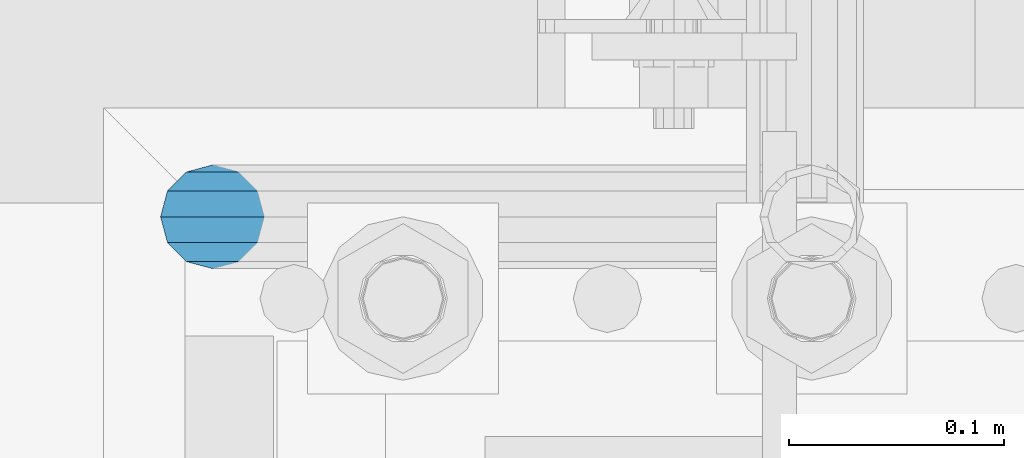
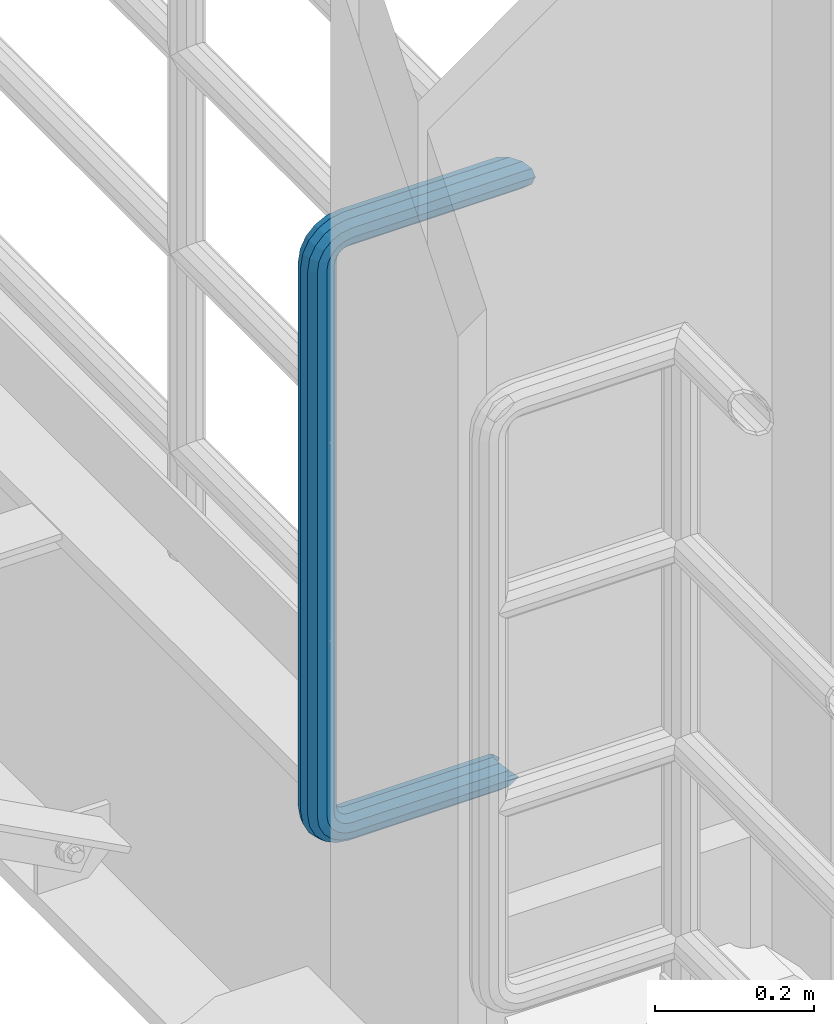
# One storey, part 990 of 1876: 1 beam, 1 element without a shape of its own.
"""IFC2X3 building model written with IfcOpenShell, lengths in millimetres."""

from ifc_helpers import new_model, si_unit, frame, origin_with_axes, place, context, subcontext, project, spatial, faceted_brep, material, type_object, element, aggregate, save


model = new_model("IFC2X3")

# Units and contexts
model_context = context("Model", 3, precision=1e-05, world=origin_with_axes())
body_context = subcontext(model_context, "Body", "Model", "MODEL_VIEW")
ifc_project = project(units=[si_unit("LENGTHUNIT", "METRE", prefix="MILLI"), si_unit("AREAUNIT", "SQUARE_METRE"), si_unit("VOLUMEUNIT", "CUBIC_METRE"), si_unit("MASSUNIT", "GRAM", prefix="KILO"), si_unit("TIMEUNIT", "SECOND"), si_unit("PLANEANGLEUNIT", "RADIAN"), si_unit("SOLIDANGLEUNIT", "STERADIAN"), si_unit("THERMODYNAMICTEMPERATUREUNIT", "DEGREE_CELSIUS"), si_unit("LUMINOUSINTENSITYUNIT", "LUMEN")], contexts=[model_context])

# Site, building, storey
site_placement = place(None, origin_with_axes())
site = spatial("IfcSite", under=ifc_project, at=site_placement, CompositionType="ELEMENT")
building_placement = place(site_placement, origin_with_axes())
building = spatial("IfcBuilding", under=site, at=building_placement, Name="Undefined", CompositionType="ELEMENT")
storey_placement = place(building_placement, origin_with_axes())
storey = spatial("IfcBuildingStorey", under=building, at=storey_placement, Name="Undefined", CompositionType="ELEMENT", Elevation=0.0)

# Assembly, beam
assembly_placement = place(storey_placement, origin_with_axes())
assembly = element("IfcElementAssembly", 1, at=assembly_placement, inside=storey, Name="RAIL", AssemblyPlace="NOTDEFINED", PredefinedType="RIGID_FRAME")
ifc_material = material()
beam_type = type_object("IfcBeamType", Name="PIPE1-1/2SCH40", PredefinedType="NOTDEFINED")
beam_placement = place(assembly_placement, frame((7620.00000000001, -4356.1, 9229.725), z_axis=(0.0, 0.0, 1.0), x_axis=(-1.0, 0.0, 0.0)))
beam = element("IfcBeam", 2, at=beam_placement, type_object=beam_type, material=ifc_material, Name="RAIL", ObjectType="PIPE1-1/2SCH40", context=body_context, shape_type="Brep", body=[
    faceted_brep([(1.20714750983051e-12, 24.1299999999974, -914.399963378906), (12.0650000000014, 20.8971929933159, -926.464963378905), (12.0650000000014, 20.8971929933177, -902.334963378908), (12.0650000000014, -20.8971929933195, -902.334963378908), (12.0650000000014, -20.8971929933195, -926.464963378905), (1.52133659548828e-12, -24.130000000001, -914.399963378906), (20.8971929933199, -12.0650000000023, -893.502770385589), (20.8971929933199, -12.0650000000005, -898.533841947723), (15.2545715621378, -17.7076214311819, -904.176463378906), (12.5151929933181, -20.4470000000019, -914.399963378906), (15.2545715621376, -17.7076214311819, -924.623463378906), (20.8971929933199, -12.0650000000005, -930.26608481009), (20.8971929933199, -12.0650000000023, -935.297156372224), (24.1300000000014, -1.81898940354586e-12, -934.846963378906), (24.1300000000014, -1.81898940354586e-12, -938.529963378907), (21.3906214311813, -10.2235000000019, -932.107584810088), (21.3906214311823, 10.2234999999982, -932.107584810088), (20.8971929933199, 12.0650000000005, -930.266084810086), (20.8971929933199, 12.0649999999987, -935.297156372224), (15.2545715621413, 17.7076214311783, -924.623463378906), (12.5151929933216, 20.4469999999983, -914.399963378906), (15.2545715621411, 17.7076214311783, -904.176463378906), (20.8971929933199, 12.0650000000005, -898.533841947727), (20.8971929933199, 12.0649999999987, -893.502770385589), (21.3906214311822, 10.2234999999982, -896.692341947724), (24.1300000000014, 0.0, -893.952963378906), (24.1300000000014, 0.0, -890.269963378905), (21.3906214311814, -10.2235000000019, -896.692341947724), (241.299995422363, -20.8971929933177, 12.0649999999987), (241.299995422363, -24.1299999999992, 0.0), (253.073542436527, -24.1299999999992, -1.86474665447167), (256.801832473661, -20.8971929933177, 9.60975021462946), (241.299995422363, -12.0650000000005, 20.8971929933177), (259.531130206197, -12.0650000000005, 18.0096649141014), (241.299995422363, 0.0, 24.130000000001), (260.530122510796, 0.0, 21.084247083727), (241.299995422363, 12.0650000000005, 20.8971929933177), (259.531130206197, 12.0650000000005, 18.0096649141014), (241.299995422363, 20.8971929933177, 12.0649999999987), (256.801832473661, 20.8971929933177, 9.60975021462946), (241.299995422363, 24.1299999999992, 0.0), (253.073542436527, 24.1299999999992, -1.86474665447167), (241.299995422363, 20.8971929933177, -12.0649999999987), (249.345252399393, 20.8971929933177, -13.3392435235728), (241.299995422363, 12.0650000000005, -20.8971929933177), (246.615954666858, 12.0650000000005, -21.7391582230448), (241.299995422363, 0.0, -24.130000000001), (245.616962362259, 0.0, -24.8137403926739), (241.299995422363, -12.0650000000005, -20.8971929933177), (246.615954666858, -12.0650000000005, -21.7391582230448), (241.299995422363, -20.8971929933177, -12.0649999999987), (249.345252399393, -20.8971929933177, -13.3392435235728), (267.334993896485, 20.8971929933177, -38.0999984741211), (279.399993896485, 24.1299999999992, -38.0999984741211), (279.399993896484, 24.1299999999992, -876.299964904785), (267.334993896484, 20.8971929933177, -876.299964904785), (291.464993896486, 20.8971929933177, -38.0999984741211), (291.464993896484, 20.8971929933177, -876.299964904785), (300.297186889804, 12.0650000000005, -38.0999984741211), (300.297186889803, 12.0650000000005, -876.299964904785), (303.529993896486, 0.0, -38.0999984741211), (303.529993896484, 0.0, -876.299964904785), (300.297186889804, -12.0650000000005, -38.0999984741211), (300.297186889803, -12.0650000000005, -876.299964904785), (291.464993896486, -20.8971929933177, -38.0999984741211), (291.464993896484, -20.8971929933177, -876.299964904785), (279.399993896484, -24.1299999999992, -38.0999984741211), (279.399993896484, -24.1299999999992, -876.299964904785), (267.334993896485, -20.8971929933177, -38.0999984741211), (267.334993896484, -20.8971929933177, -876.299964904785), (258.502800903167, -12.0650000000005, -38.0999984741211), (258.502800903166, -12.0650000000005, -876.299964904785), (255.269993896485, 0.0, -38.0999984741211), (255.269993896484, 0.0, -876.299964904785), (258.502800903167, 12.0650000000005, -38.0999984741211), (258.502800903166, 12.0650000000005, -876.299964904785), (257.660835673438, 12.0650000000005, -881.615924149282), (254.586253503809, 0.0, -880.616931844681), (257.660835673438, -12.0650000000005, -881.615924149282), (266.06075037291, -20.8971929933177, -884.345221881817), (277.535247242011, -24.130000000001, -888.073511918952), (289.009744111112, -20.8971929933195, -891.801801956084), (297.409658810584, -12.0650000000005, -894.531099688622), (300.484240980214, 0.0, -895.53009199322), (297.409658810584, 12.0650000000005, -894.531099688622), (289.009744111112, 20.8971929933177, -891.801801956084), (277.535247242011, 24.1299999999992, -888.073511918952), (266.06075037291, 20.8971929933177, -884.345221881817), (241.299995422364, -1.81898940354586e-12, -938.529963378911), (241.299995422364, -12.0650000000005, -935.297156372228), (241.299995422364, -20.8971929933195, -926.464963378909), (241.299995422363, -24.130000000001, -914.399963378906), (241.299995422363, -20.8971929933195, -902.334963378908), (241.299995422363, -12.0650000000005, -893.502770385589), (241.299995422363, 0.0, -890.269963378909), (241.299995422364, 20.8971929933177, -926.464963378909), (241.299995422364, 12.0649999999987, -935.297156372228), (241.299995422364, 24.1299999999992, -914.39996337891), (241.299995422363, 20.8971929933177, -902.334963378908), (241.299995422363, 12.0649999999987, -893.502770385589), (260.530122510801, 0.0, -935.484210462637), (259.531130206202, 12.0649999999987, -932.409628293008), (259.531130206201, -12.0650000000005, -932.409628293008), (256.801832473666, -20.8971929933195, -924.009713593536), (253.07354243653, -24.130000000001, -912.535216724435), (249.345252399395, -20.8971929933195, -901.060719855333), (246.615954666859, -12.0650000000005, -892.660805155861), (245.61696236226, 0.0, -889.586222986232), (246.615954666859, 12.0649999999987, -892.660805155861), (249.345252399395, 20.8971929933177, -901.060719855333), (253.07354243653, 24.1299999999992, -912.535216724435), (256.801832473666, 20.8971929933177, -924.009713593536), (275.977674493594, 12.0649999999987, -924.029695422345), (270.786241706733, 20.8971929933177, -916.884301193139), (277.877870775644, 0.0, -926.645091230272), (275.977674493608, -12.0650000000005, -924.029695422334), (270.786241706733, -20.8971929933195, -916.884301193139), (263.694612637823, -24.130000000001, -907.123511156005), (256.602983568912, -20.8971929933195, -897.362721118872), (251.411550782037, -12.0650000000005, -890.21732688968), (249.511354500001, 0.0, -887.601931081743), (251.411550782037, 12.0650000000005, -890.21732688968), (256.602983568912, 20.8971929933177, -897.362721118872), (263.694612637823, 24.1299999999992, -907.123511156005), (281.884331710718, 20.8971929933177, -905.786211189152), (272.123541673585, 24.1299999999992, -898.694582120243), (289.029725939912, 12.0650000000005, -910.977643976028), (291.645121747852, 0.0, -912.877840258065), (289.029725939912, -12.0650000000005, -910.977643976028), (281.884331710718, -20.8971929933195, -905.786211189152), (272.123541673585, -24.130000000001, -898.694582120243), (262.362751636451, -20.8971929933195, -891.602953051333), (255.217357407258, -12.0650000000005, -886.411520264461), (252.601961599318, 0.0, -884.511323982424), (255.217357407258, 12.0650000000005, -886.411520264461), (262.362751636451, 20.8971929933177, -891.602953051333), (266.060750372911, 20.8971929933177, -30.0547414970897), (257.660835673439, 12.0650000000005, -32.7840392296275), (277.535247242011, 24.1299999999992, -26.3264514599541), (289.009744111112, 20.8971929933177, -22.5981614228222), (297.409658810584, 12.0650000000005, -19.8688636902843), (300.484240980213, 0.0, -18.8698713856866), (297.409658810584, -12.0650000000005, -19.8688636902843), (289.009744111112, -20.8971929933177, -22.5981614228222), (277.535247242011, -24.1299999999992, -26.3264514599541), (266.060750372911, -20.8971929933177, -30.0547414970897), (257.660835673439, -12.0650000000005, -32.7840392296275), (254.58625350381, 0.0, -33.7830315342253), (255.217357407257, 12.0650000000005, -27.9884431144455), (252.601961599318, 0.0, -29.8886393964822), (262.362751636451, 20.8971929933177, -22.7970103275729), (272.123541673583, 24.1299999999992, -15.7053812586601), (281.884331710716, 20.8971929933177, -8.61375218975081), (289.029725939909, 12.0650000000005, -3.42231940287456), (291.645121747848, 0.0, -1.52212312084157), (289.029725939909, -12.0650000000005, -3.42231940287456), (281.884331710716, -20.8971929933177, -8.61375218975081), (272.123541673583, -24.1299999999992, -15.7053812586601), (262.362751636451, -20.8971929933177, -22.7970103275729), (255.217357407257, -12.0650000000005, -27.9884431144455), (249.511354500002, 0.0, -26.7980322971671), (251.411550782037, -12.0650000000005, -24.1826364892258), (251.411550782037, 12.0650000000005, -24.1826364892258), (256.602983568912, 20.8971929933177, -17.037242260034), (263.694612637822, 24.1299999999992, -7.27645222290084), (270.786241706732, 20.8971929933177, 2.48433781423228), (275.977674493607, 12.0650000000005, 9.62973204342416), (277.877870775642, 0.0, 12.2451278513654), (275.977674493607, -12.0650000000005, 9.62973204342416), (270.786241706732, -20.8971929933177, 2.48433781423228), (263.694612637822, -24.1299999999992, -7.27645222290084), (256.602983568912, -20.8971929933177, -17.037242260034), (24.1299999999854, -24.1299999999992, 0.0), (20.8971929933039, -20.8971929933177, -12.0649999999987), (12.0649999999854, -12.0650000000005, -20.8971929933177), (20.8971929933249, -12.0650000000005, -20.8971929933177), (16.4810997545745, -16.4810997545883, -16.48109323873), (24.1300000000063, 0.0, -24.130000000001), (-1.45519152283669e-11, 0.0, -24.130000000001), (20.8971929933249, 12.0650000000005, -20.8971929933177), (-12.0650000000145, 12.0650000000005, -20.8971929933177), (-20.897192993333, 20.8971929933177, -12.0649999999987), (-12.0649999999986, 20.8971929933177, -12.0649999999987), (12.0650000000064, 20.8971929933177, -12.0649999999987), (-16.481093238746, 16.4810932387318, -16.4810997545865), (0.0, 24.1299999999992, 0.0), (-24.1300000000145, 24.1299999999992, 0.0), (-20.897192993333, 20.8971929933177, 12.0649999999987), (-12.0650000000145, 12.0650000000005, 20.8971929933177), (-1.45519152283669e-11, 0.0, 24.130000000001), (12.0649999999854, -12.0650000000005, 20.8971929933177), (20.8971929933039, -20.8971929933177, 12.0649999999987), (241.299995422363, -17.7076214311801, 10.2235000000001), (241.299995422363, -20.4470000000001, 0.0), (20.4469999999854, -20.4470000000001, 0.0), (17.7076214311658, -17.7076214311801, 10.2235000000001), (241.299995422363, 0.0, 20.4470000000001), (241.299995422363, -10.2235000000001, 17.7076214311819), (10.2234999999854, -10.2235000000001, 17.7076214311819), (-1.45519152283669e-11, 0.0, 20.4470000000001), (241.299995422363, 10.2235000000001, 17.7076214311819), (-10.2235000000145, 10.2235000000001, 17.7076214311819), (241.299995422363, 17.7076214311801, 10.2235000000001), (-17.7076214311949, 17.7076214311801, 10.2235000000001), (241.299995422363, 20.4470000000001, 0.0), (-20.4470000000145, 20.4470000000001, 0.0), (241.299995422363, 17.7076214311801, -10.2235000000001), (-17.7076214311949, 17.7076214311801, -10.2235000000001), (241.299995422363, 10.2235000000001, -17.7076214311819), (-10.2235000000145, 10.2235000000001, -17.7076214311819), (241.299995422363, 0.0, -20.4470000000001), (-1.45519152283669e-11, 0.0, -20.4470000000001), (241.299995422363, -10.2235000000001, -17.7076214311819), (10.2234999999854, -10.2235000000001, -17.7076214311819), (241.299995422363, -17.7076214311801, -10.2235000000001), (17.7076214311658, -17.7076214311801, -10.2235000000001), (258.545498388721, -10.2235000000001, 14.9762020957387), (256.23277767852, -17.7076214311801, 7.85837963987069), (253.073542436527, -20.4470000000001, -1.86474665447167), (249.914307194535, -17.7076214311801, -11.5878729488177), (247.601586484334, -10.2235000000001, -18.7056954046857), (246.755071952542, 0.0, -21.31099924316), (247.601586484334, 10.2235000000001, -18.7056954046857), (249.914307194535, 17.7076214311801, -11.5878729488177), (253.073542436527, 20.4470000000001, -1.86474665447167), (256.23277767852, 17.7076214311801, 7.85837963987069), (258.545498388721, 10.2235000000001, 14.9762020957387), (259.392012920513, 0.0, 17.5815059342131), (275.713057691449, 0.0, 9.26551826108334), (274.10289136825, -10.2235000000001, 7.04931444488102), (274.10289136825, 10.2235000000001, 7.04931444488102), (269.703835164635, 17.7076214311801, 0.994533019089431), (263.694612637822, 20.4470000000001, -7.27645222290084), (257.685390111009, 17.7076214311801, -15.5474374648911), (253.286333907394, 10.2235000000001, -21.6022188906827), (251.676167584195, 0.0, -23.818422706885), (253.286333907394, -10.2235000000001, -21.6022188906827), (257.685390111009, -17.7076214311801, -15.5474374648911), (263.694612637822, -20.4470000000001, -7.27645222290084), (269.703835164635, -17.7076214311801, 0.994533019089431), (286.449308341364, -10.2235000000001, -5.29710252823133), (280.394526915574, -17.7076214311801, -9.69615873184739), (288.665512157566, 0.0, -3.68693620503473), (286.449308341364, 10.2235000000001, -5.29710252823133), (280.394526915574, 17.7076214311801, -9.69615873184739), (272.123541673583, 20.4470000000001, -15.7053812586601), (263.852556431592, 17.7076214311801, -21.7146037854764), (257.797775005802, 10.2235000000001, -26.1136599890888), (255.581571189601, 0.0, -27.723826312289), (257.797775005802, -10.2235000000001, -26.1136599890888), (263.852556431592, -17.7076214311801, -21.7146037854764), (272.123541673583, -20.4470000000001, -15.7053812586601), (287.258373536355, -17.7076214311801, -23.1672162179639), (277.535247242011, -20.4470000000001, -26.3264514599541), (294.376195992223, -10.2235000000001, -20.8544955077632), (296.981499830698, 0.0, -20.00798097597), (294.376195992223, 10.2235000000001, -20.8544955077632), (287.258373536355, 17.7076214311801, -23.1672162179639), (277.535247242011, 20.4470000000001, -26.3264514599541), (267.812120947668, 17.7076214311801, -29.485686701948), (260.6942984918, 10.2235000000001, -31.7984074121487), (258.088994653325, 0.0, -32.6449219439419), (260.6942984918, -10.2235000000001, -31.7984074121487), (267.812120947668, -17.7076214311801, -29.485686701948), (279.399993896484, -20.4470000000001, -38.0999984741211), (269.176493896485, -17.7076214311801, -38.0999984741211), (289.623493896486, -17.7076214311801, -38.0999984741211), (297.107615327666, -10.2235000000001, -38.0999984741211), (299.846993896486, 0.0, -38.0999984741211), (297.107615327666, 10.2235000000001, -38.0999984741211), (289.623493896486, 17.7076214311801, -38.0999984741211), (279.399993896485, 20.4470000000001, -38.0999984741211), (269.176493896485, 17.7076214311801, -38.0999984741211), (261.692372465305, 10.2235000000001, -38.0999984741211), (258.952993896485, 0.0, -38.0999984741211), (261.692372465305, -10.2235000000001, -38.0999984741211), (269.176493896484, -17.7076214311801, -876.299964904785), (261.692372465304, -10.2235000000001, -876.299964904785), (258.952993896484, 0.0, -876.299964904785), (261.692372465304, 10.2235000000001, -876.299964904785), (269.176493896484, 17.7076214311801, -876.299964904785), (279.399993896484, 20.4470000000001, -876.299964904785), (289.623493896484, 17.7076214311801, -876.299964904785), (297.107615327665, 10.2235000000001, -876.299964904785), (299.846993896484, 0.0, -876.299964904785), (297.107615327665, -10.2235000000001, -876.299964904785), (289.623493896484, -17.7076214311801, -876.299964904785), (279.399993896484, -20.4470000000001, -876.299964904785), (277.535247242011, -20.4470000000001, -888.073511918952), (267.812120947667, -17.7076214311801, -884.914276676958), (260.694298491799, -10.2235000000001, -882.601555966758), (258.088994653324, 0.0, -881.755041434964), (260.694298491799, 10.2235000000001, -882.601555966758), (267.812120947668, 17.7076214311801, -884.914276676958), (277.535247242011, 20.4470000000001, -888.073511918952), (287.258373536355, 17.7076214311801, -891.232747160942), (294.376195992223, 10.2235000000001, -893.545467871143), (296.981499830699, 0.0, -894.391982402936), (294.376195992223, -10.2235000000001, -893.545467871143), (287.258373536355, -17.7076214311801, -891.232747160942), (280.394526915577, -17.7076214311801, -904.703804647055), (272.123541673585, -20.4470000000001, -898.694582120243), (286.449308341367, -10.2235000000001, -909.102860850671), (288.665512157569, 0.0, -910.713027173868), (286.449308341367, 10.2235000000001, -909.102860850671), (280.394526915577, 17.7076214311801, -904.703804647055), (272.123541673585, 20.4470000000001, -898.694582120243), (263.852556431593, 17.7076214311801, -892.68535959343), (257.797775005802, 10.2235000000001, -888.286303389817), (255.581571189601, 0.0, -886.676137066617), (257.797775005802, -10.2235000000001, -888.286303389817), (263.852556431593, -17.7076214311801, -892.68535959343), (263.694612637823, -20.4470000000001, -907.123511156005), (257.685390111009, -17.7076214311801, -898.852525914015), (269.703835164636, -17.7076214311801, -915.394496397999), (274.102891368238, -10.2235000000001, -921.449277823798), (275.71305769145, 0.0, -923.66548163999), (274.102891368251, 10.2235000000001, -921.449277823787), (269.703835164636, 17.7076214311801, -915.394496397999), (263.694612637823, 20.4470000000001, -907.123511156005), (257.685390111009, 17.7076214311801, -898.852525914015), (253.286333907394, 10.2235000000001, -892.797744488227), (251.676167584195, 0.0, -890.581540672025), (253.286333907394, -10.2235000000001, -892.797744488227), (249.914307194537, -17.7076214311801, -902.812090430092), (247.601586484335, -10.2235000000001, -895.694267974224), (253.07354243653, -20.4470000000001, -912.535216724435), (256.232777678524, -17.7076214311819, -922.258343018777), (258.545498388725, -10.2235000000001, -929.376165474645), (259.392012920517, 0.0, -931.981469313119), (258.545498388725, 10.2235000000001, -929.376165474645), (256.232777678524, 17.7076214311801, -922.258343018777), (253.07354243653, 20.4470000000001, -912.535216724435), (249.914307194537, 17.7076214311801, -902.812090430092), (247.601586484335, 10.2235000000001, -895.694267974224), (246.755071952543, 0.0, -893.088964135746), (241.299995422363, -10.2235000000001, -896.692341947728), (241.299995422363, 0.0, -893.95296337891), (241.299995422363, -17.7076214311819, -904.17646337891), (241.299995422363, -20.4470000000001, -914.399963378906), (241.299995422364, -17.7076214311819, -924.62346337891), (241.299995422364, -10.2235000000001, -932.107584810088), (241.299995422364, -1.81898940354586e-12, -934.84696337891), (241.299995422364, 10.2234999999982, -932.107584810088), (241.299995422364, 17.7076214311801, -924.62346337891), (241.299995422364, 20.4470000000001, -914.39996337891), (241.299995422363, 17.7076214311801, -904.17646337891), (241.299995422363, 10.2235000000001, -896.692341947728)], [[[0, 1, 2]], [[3, 4, 5]], [[6, 7, 8, 9, 10, 11, 12, 4, 3]], [[13, 14, 12, 11, 15]], [[16, 17, 18, 14, 13]], [[2, 1, 18, 17, 19, 20, 21, 22, 23]], [[23, 22, 24, 25, 26]], [[26, 25, 27, 7, 6]], [[28, 29, 30, 31]], [[32, 28, 31, 33]], [[34, 32, 33, 35]], [[36, 34, 35, 37]], [[38, 36, 37, 39]], [[40, 38, 39, 41]], [[42, 40, 41, 43]], [[44, 42, 43, 45]], [[46, 44, 45, 47]], [[48, 46, 47, 49]], [[50, 48, 49, 51]], [[52, 53, 54, 55]], [[53, 56, 57, 54]], [[56, 58, 59, 57]], [[58, 60, 61, 59]], [[60, 62, 63, 61]], [[62, 64, 65, 63]], [[64, 66, 67, 65]], [[66, 68, 69, 67]], [[68, 70, 71, 69]], [[70, 72, 73, 71]], [[72, 74, 75, 73]], [[73, 75, 76, 77]], [[71, 73, 77, 78]], [[69, 71, 78, 79]], [[67, 69, 79, 80]], [[65, 67, 80, 81]], [[63, 65, 81, 82]], [[61, 63, 82, 83]], [[59, 61, 83, 84]], [[57, 59, 84, 85]], [[54, 57, 85, 86]], [[55, 54, 86, 87]], [[88, 89, 12, 14]], [[89, 90, 4, 12]], [[90, 91, 5, 4]], [[91, 92, 3, 5]], [[92, 93, 6, 3]], [[93, 94, 26, 6]], [[95, 96, 18, 1]], [[97, 95, 1, 0]], [[98, 97, 0, 2]], [[99, 98, 2, 23]], [[94, 99, 23, 26]], [[96, 88, 14, 18]], [[100, 88, 96, 101]], [[102, 89, 88, 100]], [[103, 90, 89, 102]], [[104, 91, 90, 103]], [[105, 92, 91, 104]], [[106, 93, 92, 105]], [[107, 94, 93, 106]], [[108, 99, 94, 107]], [[109, 98, 99, 108]], [[110, 97, 98, 109]], [[111, 95, 97, 110]], [[101, 96, 95, 111]], [[112, 101, 111, 113]], [[114, 100, 101, 112]], [[115, 102, 100, 114]], [[116, 103, 102, 115]], [[117, 104, 103, 116]], [[118, 105, 104, 117]], [[119, 106, 105, 118]], [[120, 107, 106, 119]], [[121, 108, 107, 120]], [[122, 109, 108, 121]], [[123, 110, 109, 122]], [[113, 111, 110, 123]], [[124, 113, 123, 125]], [[126, 112, 113, 124]], [[127, 114, 112, 126]], [[128, 115, 114, 127]], [[129, 116, 115, 128]], [[130, 117, 116, 129]], [[131, 118, 117, 130]], [[132, 119, 118, 131]], [[133, 120, 119, 132]], [[134, 121, 120, 133]], [[135, 122, 121, 134]], [[125, 123, 122, 135]], [[86, 125, 135, 87]], [[85, 124, 125, 86]], [[84, 126, 124, 85]], [[83, 127, 126, 84]], [[82, 128, 127, 83]], [[81, 129, 128, 82]], [[80, 130, 129, 81]], [[79, 131, 130, 80]], [[78, 132, 131, 79]], [[77, 133, 132, 78]], [[76, 134, 133, 77]], [[87, 135, 134, 76]], [[75, 55, 87, 76]], [[74, 52, 55, 75]], [[136, 52, 74, 137]], [[138, 53, 52, 136]], [[139, 56, 53, 138]], [[140, 58, 56, 139]], [[141, 60, 58, 140]], [[142, 62, 60, 141]], [[143, 64, 62, 142]], [[144, 66, 64, 143]], [[145, 68, 66, 144]], [[146, 70, 68, 145]], [[147, 72, 70, 146]], [[137, 74, 72, 147]], [[148, 137, 147, 149]], [[150, 136, 137, 148]], [[151, 138, 136, 150]], [[152, 139, 138, 151]], [[153, 140, 139, 152]], [[154, 141, 140, 153]], [[155, 142, 141, 154]], [[156, 143, 142, 155]], [[157, 144, 143, 156]], [[158, 145, 144, 157]], [[159, 146, 145, 158]], [[149, 147, 146, 159]], [[160, 149, 159, 161]], [[162, 148, 149, 160]], [[163, 150, 148, 162]], [[164, 151, 150, 163]], [[165, 152, 151, 164]], [[166, 153, 152, 165]], [[167, 154, 153, 166]], [[168, 155, 154, 167]], [[169, 156, 155, 168]], [[170, 157, 156, 169]], [[171, 158, 157, 170]], [[161, 159, 158, 171]], [[49, 161, 171, 51]], [[47, 160, 161, 49]], [[45, 162, 160, 47]], [[43, 163, 162, 45]], [[41, 164, 163, 43]], [[39, 165, 164, 41]], [[37, 166, 165, 39]], [[35, 167, 166, 37]], [[33, 168, 167, 35]], [[31, 169, 168, 33]], [[30, 170, 169, 31]], [[51, 171, 170, 30]], [[29, 50, 51, 30]], [[50, 29, 172, 173]], [[174, 175, 48, 50, 173, 176]], [[177, 46, 48, 175, 174, 178]], [[179, 44, 46, 177, 178, 180]], [[181, 182, 183, 42, 44, 179, 180, 184]], [[185, 40, 42, 183, 182, 181, 186]], [[38, 40, 185, 186, 187]], [[36, 38, 187, 188]], [[34, 36, 188, 189]], [[32, 34, 189, 190]], [[28, 32, 190, 191]], [[29, 28, 191, 172]], [[192, 193, 194, 195]], [[196, 197, 198, 199]], [[200, 196, 199, 201]], [[202, 200, 201, 203]], [[204, 202, 203, 205]], [[206, 204, 205, 207]], [[208, 206, 207, 209]], [[210, 208, 209, 211]], [[212, 210, 211, 213]], [[214, 212, 213, 215]], [[193, 214, 215, 194]], [[190, 189, 188, 187, 186, 181, 184, 180, 178, 174, 176, 173, 172, 191], [213, 211, 209, 207, 205, 203, 201, 199, 198, 195, 194, 215]], [[197, 192, 195, 198]], [[192, 197, 216, 217]], [[193, 192, 217, 218]], [[214, 193, 218, 219]], [[212, 214, 219, 220]], [[210, 212, 220, 221]], [[208, 210, 221, 222]], [[206, 208, 222, 223]], [[204, 206, 223, 224]], [[202, 204, 224, 225]], [[200, 202, 225, 226]], [[196, 200, 226, 227]], [[197, 196, 227, 216]], [[227, 228, 229, 216]], [[226, 230, 228, 227]], [[225, 231, 230, 226]], [[224, 232, 231, 225]], [[223, 233, 232, 224]], [[222, 234, 233, 223]], [[221, 235, 234, 222]], [[220, 236, 235, 221]], [[219, 237, 236, 220]], [[218, 238, 237, 219]], [[217, 239, 238, 218]], [[216, 229, 239, 217]], [[229, 240, 241, 239]], [[228, 242, 240, 229]], [[230, 243, 242, 228]], [[231, 244, 243, 230]], [[232, 245, 244, 231]], [[233, 246, 245, 232]], [[234, 247, 246, 233]], [[235, 248, 247, 234]], [[236, 249, 248, 235]], [[237, 250, 249, 236]], [[238, 251, 250, 237]], [[239, 241, 251, 238]], [[241, 252, 253, 251]], [[240, 254, 252, 241]], [[242, 255, 254, 240]], [[243, 256, 255, 242]], [[244, 257, 256, 243]], [[245, 258, 257, 244]], [[246, 259, 258, 245]], [[247, 260, 259, 246]], [[248, 261, 260, 247]], [[249, 262, 261, 248]], [[250, 263, 262, 249]], [[251, 253, 263, 250]], [[253, 264, 265, 263]], [[252, 266, 264, 253]], [[254, 267, 266, 252]], [[255, 268, 267, 254]], [[256, 269, 268, 255]], [[257, 270, 269, 256]], [[258, 271, 270, 257]], [[259, 272, 271, 258]], [[260, 273, 272, 259]], [[261, 274, 273, 260]], [[262, 275, 274, 261]], [[263, 265, 275, 262]], [[275, 265, 276, 277]], [[274, 275, 277, 278]], [[273, 274, 278, 279]], [[272, 273, 279, 280]], [[271, 272, 280, 281]], [[270, 271, 281, 282]], [[269, 270, 282, 283]], [[268, 269, 283, 284]], [[267, 268, 284, 285]], [[266, 267, 285, 286]], [[264, 266, 286, 287]], [[265, 264, 287, 276]], [[276, 287, 288, 289]], [[277, 276, 289, 290]], [[278, 277, 290, 291]], [[279, 278, 291, 292]], [[280, 279, 292, 293]], [[281, 280, 293, 294]], [[282, 281, 294, 295]], [[283, 282, 295, 296]], [[284, 283, 296, 297]], [[285, 284, 297, 298]], [[286, 285, 298, 299]], [[287, 286, 299, 288]], [[299, 300, 301, 288]], [[298, 302, 300, 299]], [[297, 303, 302, 298]], [[296, 304, 303, 297]], [[295, 305, 304, 296]], [[294, 306, 305, 295]], [[293, 307, 306, 294]], [[292, 308, 307, 293]], [[291, 309, 308, 292]], [[290, 310, 309, 291]], [[289, 311, 310, 290]], [[288, 301, 311, 289]], [[301, 312, 313, 311]], [[300, 314, 312, 301]], [[302, 315, 314, 300]], [[303, 316, 315, 302]], [[304, 317, 316, 303]], [[305, 318, 317, 304]], [[306, 319, 318, 305]], [[307, 320, 319, 306]], [[308, 321, 320, 307]], [[309, 322, 321, 308]], [[310, 323, 322, 309]], [[311, 313, 323, 310]], [[313, 324, 325, 323]], [[312, 326, 324, 313]], [[314, 327, 326, 312]], [[315, 328, 327, 314]], [[316, 329, 328, 315]], [[317, 330, 329, 316]], [[318, 331, 330, 317]], [[319, 332, 331, 318]], [[320, 333, 332, 319]], [[321, 334, 333, 320]], [[322, 335, 334, 321]], [[323, 325, 335, 322]], [[325, 336, 337, 335]], [[324, 338, 336, 325]], [[326, 339, 338, 324]], [[327, 340, 339, 326]], [[328, 341, 340, 327]], [[329, 342, 341, 328]], [[330, 343, 342, 329]], [[331, 344, 343, 330]], [[332, 345, 344, 331]], [[333, 346, 345, 332]], [[334, 347, 346, 333]], [[335, 337, 347, 334]], [[347, 337, 25, 24]], [[21, 346, 347, 24, 22]], [[345, 346, 21, 20]], [[344, 345, 20, 19]], [[343, 344, 19, 17, 16]], [[342, 343, 16, 13]], [[341, 342, 13, 15]], [[10, 340, 341, 15, 11]], [[339, 340, 10, 9]], [[338, 339, 9, 8]], [[336, 338, 8, 7, 27]], [[337, 336, 27, 25]]]),
])
aggregate(assembly, [beam])

save(model, "model.ifc")
